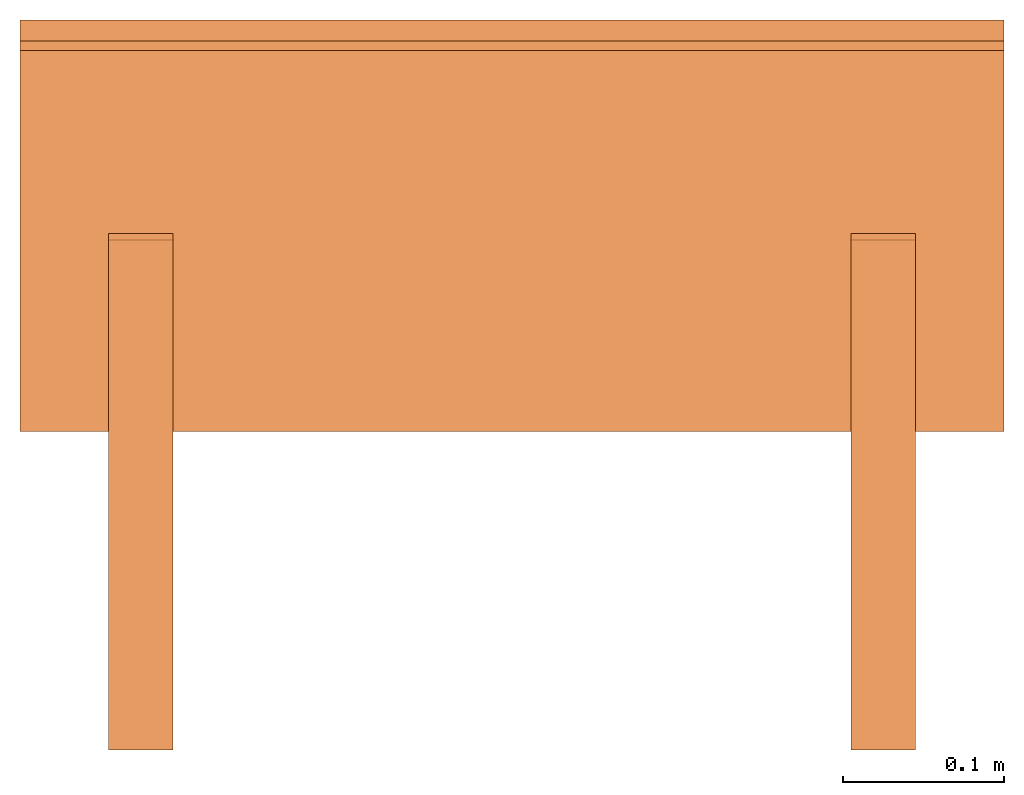
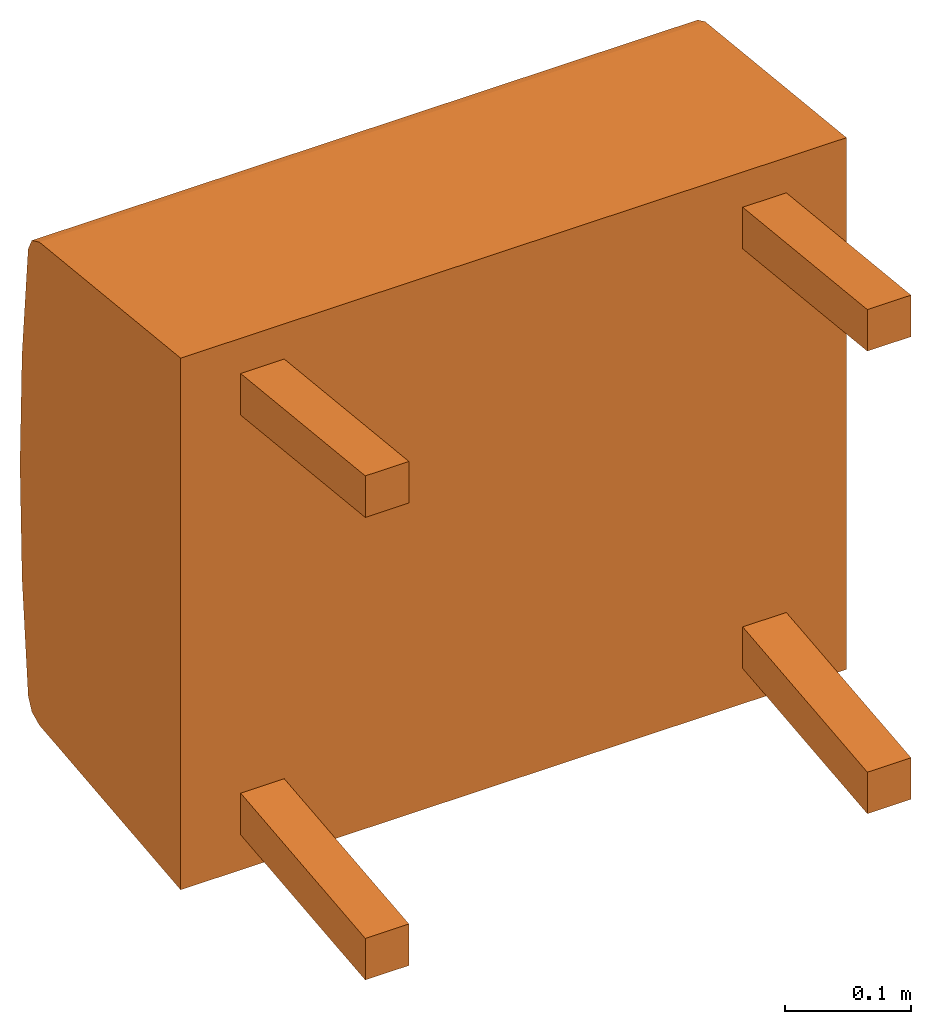
# One storey: 5 proxies, 1 element without a shape of its own.
"""IFC2X3 building model written with IfcOpenShell, lengths in metres."""

from ifc_helpers import new_model, si_unit, direction, origin_with_axes, place, context, project, spatial, faceted_brep, source, transform, mapped, element, aggregate, save


model = new_model("IFC2X3")

# Units and contexts
model_context = context("Model", 3, precision=1e-06, world=origin_with_axes(), true_north=direction((0.0, 1.0, 0.0)))
ifc_project = project(units=[si_unit("LENGTHUNIT", "METRE"), si_unit("AREAUNIT", "SQUARE_METRE"), si_unit("VOLUMEUNIT", "CUBIC_METRE")], contexts=[model_context])

# Site, building, storey
site_placement = place(None, origin_with_axes())
site = spatial("IfcSite", under=ifc_project, at=site_placement, CompositionType="ELEMENT")
building_placement = place(site_placement, origin_with_axes())
building = spatial("IfcBuilding", under=site, at=building_placement, Name="Default Building", CompositionType="ELEMENT")
storey_placement = place(building_placement, origin_with_axes())
storey = spatial("IfcBuildingStorey", under=building, at=storey_placement, Name="Default Storey", CompositionType="ELEMENT", Elevation=0.0)

# Assembly, proxies
assembly_placement = place(storey_placement, origin_with_axes())
assembly = element("IfcElementAssembly", 1, at=assembly_placement, inside=storey, Name="H-04-063-A_1-seater bench", ObjectType="H-04-063-A_1-seater bench", AssemblyPlace="NOTDEFINED", PredefinedType="NOTDEFINED")
shared_shape_1 = source(origin_with_axes(), model_context, "Body", "Brep", [
    faceted_brep([(0.3050000071525574, -0.11101193726062775, -0.25744837522506714), (0.3050000071525574, -0.11100000143051147, 0.25755399465560913), (-0.3050000071525574, -0.11101193726062775, -0.25744837522506714), (-0.3050000071525574, -0.11101193726062775, -0.25744837522506714), (0.3050000071525574, -0.11100000143051147, 0.25755399465560913), (-0.3050000071525574, -0.11100000143051147, 0.25755399465560913), (0.3050000071525574, 0.11316553503274918, -0.23389163613319397), (0.3050000071525574, -0.11101193726062775, -0.25744837522506714), (-0.3050000071525574, 0.11316553503274918, -0.23389163613319397), (-0.3050000071525574, 0.11316553503274918, -0.23389163613319397), (0.3050000071525574, -0.11101193726062775, -0.25744837522506714), (-0.3050000071525574, -0.11101193726062775, -0.25744837522506714), (0.3050000071525574, 0.12510773539543152, -0.22825226187705994), (0.3050000071525574, 0.11316553503274918, -0.23389163613319397), (-0.3050000071525574, 0.12510773539543152, -0.22825226187705994), (-0.3050000071525574, 0.12510773539543152, -0.22825226187705994), (0.3050000071525574, 0.11316553503274918, -0.23389163613319397), (-0.3050000071525574, 0.11316553503274918, -0.23389163613319397), (0.3050000071525574, 0.13093119859695435, -0.21639873087406158), (0.3050000071525574, 0.12510773539543152, -0.22825226187705994), (-0.3050000071525574, 0.13093119859695435, -0.21639873087406158), (-0.3050000071525574, 0.13093119859695435, -0.21639873087406158), (0.3050000071525574, 0.12510773539543152, -0.22825226187705994), (-0.3050000071525574, 0.12510773539543152, -0.22825226187705994), (0.3050000071525574, 0.14069734513759613, -0.10837350785732269), (0.3050000071525574, 0.13093119859695435, -0.21639873087406158), (-0.3050000071525574, 0.14069734513759613, -0.10837350785732269), (-0.3050000071525574, 0.14069734513759613, -0.10837350785732269), (0.3050000071525574, 0.13093119859695435, -0.21639873087406158), (-0.3050000071525574, 0.13093119859695435, -0.21639873087406158), (0.3050000071525574, 0.14396685361862183, 4.298765634302981e-05), (0.3050000071525574, 0.14069734513759613, -0.10837350785732269), (-0.3050000071525574, 0.14396685361862183, 4.298765634302981e-05), (-0.3050000071525574, 0.14396685361862183, 4.298765634302981e-05), (0.3050000071525574, 0.14069734513759613, -0.10837350785732269), (-0.3050000071525574, 0.14069734513759613, -0.10837350785732269), (0.3050000071525574, 0.1407279372215271, 0.10846040397882462), (0.3050000071525574, 0.14396685361862183, 4.298765634302981e-05), (-0.3050000071525574, 0.1407279372215271, 0.10846040397882462), (-0.3050000071525574, 0.1407279372215271, 0.10846040397882462), (0.3050000071525574, 0.14396685361862183, 4.298765634302981e-05), (-0.3050000071525574, 0.14396685361862183, 4.298765634302981e-05), (0.3050000071525574, 0.13099226355552673, 0.21648837625980377), (0.3050000071525574, 0.1407279372215271, 0.10846040397882462), (-0.3050000071525574, 0.13099226355552673, 0.21648837625980377), (-0.3050000071525574, 0.13099226355552673, 0.21648837625980377), (0.3050000071525574, 0.1407279372215271, 0.10846040397882462), (-0.3050000071525574, 0.1407279372215271, 0.10846040397882462), (0.3050000071525574, 0.12517030537128448, 0.2283453643321991), (0.3050000071525574, 0.13099226355552673, 0.21648837625980377), (-0.3050000071525574, 0.12517030537128448, 0.2283453643321991), (-0.3050000071525574, 0.12517030537128448, 0.2283453643321991), (0.3050000071525574, 0.13099226355552673, 0.21648837625980377), (-0.3050000071525574, 0.13099226355552673, 0.21648837625980377), (0.3050000071525574, 0.11322638392448425, 0.23398683965206146), (0.3050000071525574, 0.12517030537128448, 0.2283453643321991), (-0.3050000071525574, 0.11322638392448425, 0.23398683965206146), (-0.3050000071525574, 0.11322638392448425, 0.23398683965206146), (0.3050000071525574, 0.12517030537128448, 0.2283453643321991), (-0.3050000071525574, 0.12517030537128448, 0.2283453643321991), (0.3050000071525574, -0.11100000143051147, 0.25755399465560913), (0.3050000071525574, 0.11322638392448425, 0.23398683965206146), (-0.3050000071525574, -0.11100000143051147, 0.25755399465560913), (-0.3050000071525574, -0.11100000143051147, 0.25755399465560913), (0.3050000071525574, 0.11322638392448425, 0.23398683965206146), (-0.3050000071525574, 0.11322638392448425, 0.23398683965206146), (0.3050000071525574, 0.13099226355552673, 0.21648837625980377), (0.3050000071525574, 0.12517030537128448, 0.2283453643321991), (0.3050000071525574, 0.1407279372215271, 0.10846040397882462), (0.3050000071525574, 0.1407279372215271, 0.10846040397882462), (0.3050000071525574, 0.12517030537128448, 0.2283453643321991), (0.3050000071525574, 0.11322638392448425, 0.23398683965206146), (0.3050000071525574, 0.1407279372215271, 0.10846040397882462), (0.3050000071525574, 0.11322638392448425, 0.23398683965206146), (0.3050000071525574, -0.11100000143051147, 0.25755399465560913), (0.3050000071525574, 0.12510773539543152, -0.22825226187705994), (0.3050000071525574, 0.13093119859695435, -0.21639873087406158), (0.3050000071525574, 0.11316553503274918, -0.23389163613319397), (0.3050000071525574, 0.11316553503274918, -0.23389163613319397), (0.3050000071525574, 0.13093119859695435, -0.21639873087406158), (0.3050000071525574, 0.14069734513759613, -0.10837350785732269), (0.3050000071525574, 0.11316553503274918, -0.23389163613319397), (0.3050000071525574, 0.14069734513759613, -0.10837350785732269), (0.3050000071525574, -0.11101193726062775, -0.25744837522506714), (0.3050000071525574, -0.11101193726062775, -0.25744837522506714), (0.3050000071525574, 0.14069734513759613, -0.10837350785732269), (0.3050000071525574, -0.11100000143051147, 0.25755399465560913), (0.3050000071525574, -0.11100000143051147, 0.25755399465560913), (0.3050000071525574, 0.14069734513759613, -0.10837350785732269), (0.3050000071525574, 0.14396685361862183, 4.298765634302981e-05), (0.3050000071525574, -0.11100000143051147, 0.25755399465560913), (0.3050000071525574, 0.14396685361862183, 4.298765634302981e-05), (0.3050000071525574, 0.1407279372215271, 0.10846040397882462), (-0.3050000071525574, 0.14069734513759613, -0.10837350785732269), (-0.3050000071525574, 0.13093119859695435, -0.21639873087406158), (-0.3050000071525574, 0.12510773539543152, -0.22825226187705994), (-0.3050000071525574, 0.12517030537128448, 0.2283453643321991), (-0.3050000071525574, 0.13099226355552673, 0.21648837625980377), (-0.3050000071525574, 0.11322638392448425, 0.23398683965206146), (-0.3050000071525574, 0.11322638392448425, 0.23398683965206146), (-0.3050000071525574, 0.13099226355552673, 0.21648837625980377), (-0.3050000071525574, 0.1407279372215271, 0.10846040397882462), (-0.3050000071525574, 0.11322638392448425, 0.23398683965206146), (-0.3050000071525574, 0.1407279372215271, 0.10846040397882462), (-0.3050000071525574, -0.11100000143051147, 0.25755399465560913), (-0.3050000071525574, -0.11100000143051147, 0.25755399465560913), (-0.3050000071525574, 0.1407279372215271, 0.10846040397882462), (-0.3050000071525574, 0.14396685361862183, 4.298765634302981e-05), (-0.3050000071525574, -0.11100000143051147, 0.25755399465560913), (-0.3050000071525574, 0.14396685361862183, 4.298765634302981e-05), (-0.3050000071525574, -0.11101193726062775, -0.25744837522506714), (-0.3050000071525574, -0.11101193726062775, -0.25744837522506714), (-0.3050000071525574, 0.14396685361862183, 4.298765634302981e-05), (-0.3050000071525574, 0.14069734513759613, -0.10837350785732269), (-0.3050000071525574, -0.11101193726062775, -0.25744837522506714), (-0.3050000071525574, 0.14069734513759613, -0.10837350785732269), (-0.3050000071525574, 0.11316553503274918, -0.23389163613319397), (-0.3050000071525574, 0.11316553503274918, -0.23389163613319397), (-0.3050000071525574, 0.14069734513759613, -0.10837350785732269), (-0.3050000071525574, 0.12510773539543152, -0.22825226187705994)], [[[0, 1, 2]], [[3, 4, 5]], [[6, 7, 8]], [[9, 10, 11]], [[12, 13, 14]], [[15, 16, 17]], [[18, 19, 20]], [[21, 22, 23]], [[24, 25, 26]], [[27, 28, 29]], [[30, 31, 32]], [[33, 34, 35]], [[36, 37, 38]], [[39, 40, 41]], [[42, 43, 44]], [[45, 46, 47]], [[48, 49, 50]], [[51, 52, 53]], [[54, 55, 56]], [[57, 58, 59]], [[60, 61, 62]], [[63, 64, 65]], [[66, 67, 68]], [[69, 70, 71]], [[72, 73, 74]], [[75, 76, 77]], [[78, 79, 80]], [[81, 82, 83]], [[84, 85, 86]], [[87, 88, 89]], [[90, 91, 92]], [[93, 94, 95]], [[96, 97, 98]], [[99, 100, 101]], [[102, 103, 104]], [[105, 106, 107]], [[108, 109, 110]], [[111, 112, 113]], [[114, 115, 116]], [[117, 118, 119]]]),
])
proxy_1_placement = place(assembly_placement, origin_with_axes())
proxy_1 = element("IfcBuildingElementProxy", 2, at=proxy_1_placement, Name="1", ObjectType="1", CompositionType="ELEMENT", context=model_context, shape_type="MappedRepresentation", body=[
    mapped(shared_shape_1, transform((0.0, 0.0, 0.0), scale=1.0)),
])
shared_shape_2 = source(origin_with_axes(), model_context, "Body", "Brep", [
    faceted_brep([(0.25, -0.3086836636066437, 0.203923761844635), (0.25, -0.3086836636066437, 0.24414409697055817), (0.20999999344348907, -0.3086836636066437, 0.203923761844635), (0.20999999344348907, -0.3086836636066437, 0.203923761844635), (0.25, -0.3086836636066437, 0.24414409697055817), (0.20999999344348907, -0.3086836636066437, 0.24414409697055817), (0.25, 0.00747277494519949, 0.17069438099861145), (0.25, -0.3086836636066437, 0.203923761844635), (0.20999999344348907, 0.00747277494519949, 0.17069438099861145), (0.20999999344348907, 0.00747277494519949, 0.17069438099861145), (0.25, -0.3086836636066437, 0.203923761844635), (0.20999999344348907, -0.3086836636066437, 0.203923761844635), (0.25, 0.011653914116322994, 0.21047525107860565), (0.25, 0.00747277494519949, 0.17069438099861145), (0.20999999344348907, 0.011653914116322994, 0.21047525107860565), (0.20999999344348907, 0.011653914116322994, 0.21047525107860565), (0.25, 0.00747277494519949, 0.17069438099861145), (0.20999999344348907, 0.00747277494519949, 0.17069438099861145), (0.25, -0.3086836636066437, 0.24414409697055817), (0.25, 0.011653914116322994, 0.21047525107860565), (0.20999999344348907, -0.3086836636066437, 0.24414409697055817), (0.20999999344348907, -0.3086836636066437, 0.24414409697055817), (0.25, 0.011653914116322994, 0.21047525107860565), (0.20999999344348907, 0.011653914116322994, 0.21047525107860565), (0.25, 0.00747277494519949, 0.17069438099861145), (0.25, 0.011653914116322994, 0.21047525107860565), (0.25, -0.3086836636066437, 0.203923761844635), (0.25, -0.3086836636066437, 0.203923761844635), (0.25, 0.011653914116322994, 0.21047525107860565), (0.25, -0.3086836636066437, 0.24414409697055817), (0.20999999344348907, 0.011653914116322994, 0.21047525107860565), (0.20999999344348907, 0.00747277494519949, 0.17069438099861145), (0.20999999344348907, -0.3086836636066437, 0.24414409697055817), (0.20999999344348907, -0.3086836636066437, 0.24414409697055817), (0.20999999344348907, 0.00747277494519949, 0.17069438099861145), (0.20999999344348907, -0.3086836636066437, 0.203923761844635)], [[[0, 1, 2]], [[3, 4, 5]], [[6, 7, 8]], [[9, 10, 11]], [[12, 13, 14]], [[15, 16, 17]], [[18, 19, 20]], [[21, 22, 23]], [[24, 25, 26]], [[27, 28, 29]], [[30, 31, 32]], [[33, 34, 35]]]),
])
proxy_2_placement = place(assembly_placement, origin_with_axes())
proxy_2 = element("IfcBuildingElementProxy", 3, at=proxy_2_placement, Name="4", ObjectType="4", CompositionType="ELEMENT", context=model_context, shape_type="MappedRepresentation", body=[
    mapped(shared_shape_2, transform((0.0, 0.0, 0.0), scale=1.0)),
])
shared_shape_3 = source(origin_with_axes(), model_context, "Body", "Brep", [
    faceted_brep([(0.25, -0.3086836636066437, -0.2039259523153305), (0.25, 0.00747277494519949, -0.17069658637046814), (0.20999999344348907, -0.3086836636066437, -0.2039259523153305), (0.20999999344348907, -0.3086836636066437, -0.2039259523153305), (0.25, 0.00747277494519949, -0.17069658637046814), (0.20999999344348907, 0.00747277494519949, -0.17069658637046814), (0.25, -0.3086836636066437, -0.24414628744125366), (0.25, -0.3086836636066437, -0.2039259523153305), (0.20999999344348907, -0.3086836636066437, -0.24414628744125366), (0.20999999344348907, -0.3086836636066437, -0.24414628744125366), (0.25, -0.3086836636066437, -0.2039259523153305), (0.20999999344348907, -0.3086836636066437, -0.2039259523153305), (0.25, 0.011653914116322994, -0.21047745645046234), (0.25, -0.3086836636066437, -0.24414628744125366), (0.20999999344348907, 0.011653914116322994, -0.21047745645046234), (0.20999999344348907, 0.011653914116322994, -0.21047745645046234), (0.25, -0.3086836636066437, -0.24414628744125366), (0.20999999344348907, -0.3086836636066437, -0.24414628744125366), (0.25, 0.00747277494519949, -0.17069658637046814), (0.25, 0.011653914116322994, -0.21047745645046234), (0.20999999344348907, 0.00747277494519949, -0.17069658637046814), (0.20999999344348907, 0.00747277494519949, -0.17069658637046814), (0.25, 0.011653914116322994, -0.21047745645046234), (0.20999999344348907, 0.011653914116322994, -0.21047745645046234), (0.25, -0.3086836636066437, -0.24414628744125366), (0.25, 0.011653914116322994, -0.21047745645046234), (0.25, -0.3086836636066437, -0.2039259523153305), (0.25, -0.3086836636066437, -0.2039259523153305), (0.25, 0.011653914116322994, -0.21047745645046234), (0.25, 0.00747277494519949, -0.17069658637046814), (0.20999999344348907, 0.011653914116322994, -0.21047745645046234), (0.20999999344348907, -0.3086836636066437, -0.24414628744125366), (0.20999999344348907, 0.00747277494519949, -0.17069658637046814), (0.20999999344348907, 0.00747277494519949, -0.17069658637046814), (0.20999999344348907, -0.3086836636066437, -0.24414628744125366), (0.20999999344348907, -0.3086836636066437, -0.2039259523153305)], [[[0, 1, 2]], [[3, 4, 5]], [[6, 7, 8]], [[9, 10, 11]], [[12, 13, 14]], [[15, 16, 17]], [[18, 19, 20]], [[21, 22, 23]], [[24, 25, 26]], [[27, 28, 29]], [[30, 31, 32]], [[33, 34, 35]]]),
])
proxy_3_placement = place(assembly_placement, origin_with_axes())
proxy_3 = element("IfcBuildingElementProxy", 4, at=proxy_3_placement, Name="5", ObjectType="5", CompositionType="ELEMENT", context=model_context, shape_type="MappedRepresentation", body=[
    mapped(shared_shape_3, transform((0.0, 0.0, 0.0), scale=1.0)),
])
shared_shape_4 = source(origin_with_axes(), model_context, "Body", "Brep", [
    faceted_brep([(-0.20999999344348907, -0.3086836636066437, -0.2039259523153305), (-0.20999999344348907, 0.00747277494519949, -0.17069658637046814), (-0.25, -0.3086836636066437, -0.2039259523153305), (-0.25, -0.3086836636066437, -0.2039259523153305), (-0.20999999344348907, 0.00747277494519949, -0.17069658637046814), (-0.25, 0.00747277494519949, -0.17069658637046814), (-0.20999999344348907, -0.3086836636066437, -0.24414628744125366), (-0.20999999344348907, -0.3086836636066437, -0.2039259523153305), (-0.25, -0.3086836636066437, -0.24414628744125366), (-0.25, -0.3086836636066437, -0.24414628744125366), (-0.20999999344348907, -0.3086836636066437, -0.2039259523153305), (-0.25, -0.3086836636066437, -0.2039259523153305), (-0.20999999344348907, 0.011653914116322994, -0.21047745645046234), (-0.20999999344348907, -0.3086836636066437, -0.24414628744125366), (-0.25, 0.011653914116322994, -0.21047745645046234), (-0.25, 0.011653914116322994, -0.21047745645046234), (-0.20999999344348907, -0.3086836636066437, -0.24414628744125366), (-0.25, -0.3086836636066437, -0.24414628744125366), (-0.20999999344348907, 0.00747277494519949, -0.17069658637046814), (-0.20999999344348907, 0.011653914116322994, -0.21047745645046234), (-0.25, 0.00747277494519949, -0.17069658637046814), (-0.25, 0.00747277494519949, -0.17069658637046814), (-0.20999999344348907, 0.011653914116322994, -0.21047745645046234), (-0.25, 0.011653914116322994, -0.21047745645046234), (-0.20999999344348907, -0.3086836636066437, -0.24414628744125366), (-0.20999999344348907, 0.011653914116322994, -0.21047745645046234), (-0.20999999344348907, -0.3086836636066437, -0.2039259523153305), (-0.20999999344348907, -0.3086836636066437, -0.2039259523153305), (-0.20999999344348907, 0.011653914116322994, -0.21047745645046234), (-0.20999999344348907, 0.00747277494519949, -0.17069658637046814), (-0.25, 0.011653914116322994, -0.21047745645046234), (-0.25, -0.3086836636066437, -0.24414628744125366), (-0.25, 0.00747277494519949, -0.17069658637046814), (-0.25, 0.00747277494519949, -0.17069658637046814), (-0.25, -0.3086836636066437, -0.24414628744125366), (-0.25, -0.3086836636066437, -0.2039259523153305)], [[[0, 1, 2]], [[3, 4, 5]], [[6, 7, 8]], [[9, 10, 11]], [[12, 13, 14]], [[15, 16, 17]], [[18, 19, 20]], [[21, 22, 23]], [[24, 25, 26]], [[27, 28, 29]], [[30, 31, 32]], [[33, 34, 35]]]),
])
proxy_4_placement = place(assembly_placement, origin_with_axes())
proxy_4 = element("IfcBuildingElementProxy", 5, at=proxy_4_placement, Name="6", ObjectType="6", CompositionType="ELEMENT", context=model_context, shape_type="MappedRepresentation", body=[
    mapped(shared_shape_4, transform((0.0, 0.0, 0.0), scale=1.0)),
])
shared_shape_5 = source(origin_with_axes(), model_context, "Body", "Brep", [
    faceted_brep([(-0.20999999344348907, -0.3086836636066437, 0.203923761844635), (-0.20999999344348907, -0.3086836636066437, 0.24414409697055817), (-0.25, -0.3086836636066437, 0.203923761844635), (-0.25, -0.3086836636066437, 0.203923761844635), (-0.20999999344348907, -0.3086836636066437, 0.24414409697055817), (-0.25, -0.3086836636066437, 0.24414409697055817), (-0.20999999344348907, 0.00747277494519949, 0.17069438099861145), (-0.20999999344348907, -0.3086836636066437, 0.203923761844635), (-0.25, 0.00747277494519949, 0.17069438099861145), (-0.25, 0.00747277494519949, 0.17069438099861145), (-0.20999999344348907, -0.3086836636066437, 0.203923761844635), (-0.25, -0.3086836636066437, 0.203923761844635), (-0.20999999344348907, 0.011653914116322994, 0.21047525107860565), (-0.20999999344348907, 0.00747277494519949, 0.17069438099861145), (-0.25, 0.011653914116322994, 0.21047525107860565), (-0.25, 0.011653914116322994, 0.21047525107860565), (-0.20999999344348907, 0.00747277494519949, 0.17069438099861145), (-0.25, 0.00747277494519949, 0.17069438099861145), (-0.20999999344348907, -0.3086836636066437, 0.24414409697055817), (-0.20999999344348907, 0.011653914116322994, 0.21047525107860565), (-0.25, -0.3086836636066437, 0.24414409697055817), (-0.25, -0.3086836636066437, 0.24414409697055817), (-0.20999999344348907, 0.011653914116322994, 0.21047525107860565), (-0.25, 0.011653914116322994, 0.21047525107860565), (-0.20999999344348907, 0.00747277494519949, 0.17069438099861145), (-0.20999999344348907, 0.011653914116322994, 0.21047525107860565), (-0.20999999344348907, -0.3086836636066437, 0.203923761844635), (-0.20999999344348907, -0.3086836636066437, 0.203923761844635), (-0.20999999344348907, 0.011653914116322994, 0.21047525107860565), (-0.20999999344348907, -0.3086836636066437, 0.24414409697055817), (-0.25, 0.011653914116322994, 0.21047525107860565), (-0.25, 0.00747277494519949, 0.17069438099861145), (-0.25, -0.3086836636066437, 0.24414409697055817), (-0.25, -0.3086836636066437, 0.24414409697055817), (-0.25, 0.00747277494519949, 0.17069438099861145), (-0.25, -0.3086836636066437, 0.203923761844635)], [[[0, 1, 2]], [[3, 4, 5]], [[6, 7, 8]], [[9, 10, 11]], [[12, 13, 14]], [[15, 16, 17]], [[18, 19, 20]], [[21, 22, 23]], [[24, 25, 26]], [[27, 28, 29]], [[30, 31, 32]], [[33, 34, 35]]]),
])
proxy_5_placement = place(assembly_placement, origin_with_axes())
proxy_5 = element("IfcBuildingElementProxy", 6, at=proxy_5_placement, Name="7", ObjectType="7", CompositionType="ELEMENT", context=model_context, shape_type="MappedRepresentation", body=[
    mapped(shared_shape_5, transform((0.0, 0.0, 0.0), scale=1.0)),
])
aggregate(assembly, [proxy_1, proxy_2, proxy_3, proxy_4, proxy_5])

save(model, "model.ifc")
